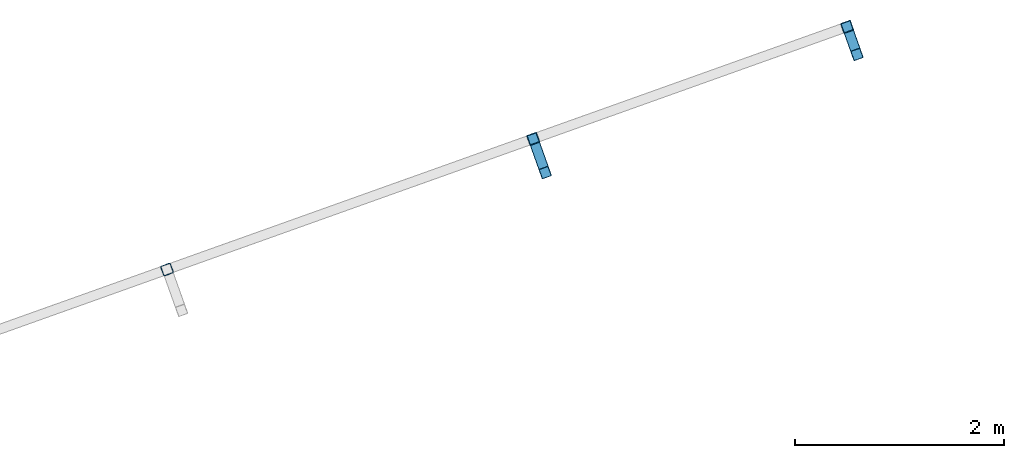
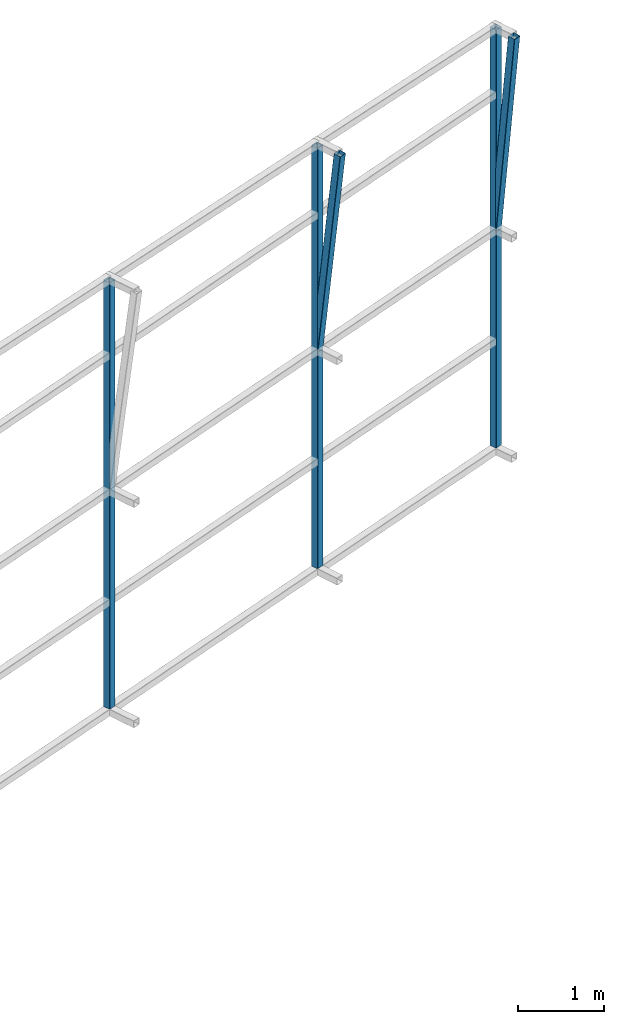
# One storey, part 139 of 215: 3 beams, 2 members, 5 elements without a shape of their own.
"""IFC2X3 building model written with IfcOpenShell, lengths in millimetres."""

from ifc_helpers import new_model, si_unit, frame, origin_with_axes, origin_2d_with_axis, place, context, subcontext, project, spatial, hollow_rectangle, extrude, material, type_object, element, aggregate, save


model = new_model("IFC2X3")

# Units and contexts
model_context = context("Model", 3, precision=1e-05, world=origin_with_axes())
body_context = subcontext(model_context, "Body", "Model", "MODEL_VIEW")
ifc_project = project(units=[si_unit("LENGTHUNIT", "METRE", prefix="MILLI"), si_unit("AREAUNIT", "SQUARE_METRE"), si_unit("VOLUMEUNIT", "CUBIC_METRE"), si_unit("MASSUNIT", "GRAM", prefix="KILO"), si_unit("TIMEUNIT", "SECOND"), si_unit("PLANEANGLEUNIT", "RADIAN"), si_unit("SOLIDANGLEUNIT", "STERADIAN"), si_unit("THERMODYNAMICTEMPERATUREUNIT", "DEGREE_CELSIUS"), si_unit("LUMINOUSINTENSITYUNIT", "LUMEN")], contexts=[model_context])

# Site, building, storey
site_placement = place(None, origin_with_axes())
site = spatial("IfcSite", under=ifc_project, at=site_placement, CompositionType="ELEMENT")
building_placement = place(site_placement, origin_with_axes())
building = spatial("IfcBuilding", under=site, at=building_placement, Name="Undefined", CompositionType="ELEMENT")
storey_placement = place(building_placement, origin_with_axes())
storey = spatial("IfcBuildingStorey", under=building, at=storey_placement, Name="Undefined", CompositionType="ELEMENT", Elevation=0.0)

# Assembly, beam
assembly_1_placement = place(storey_placement, origin_with_axes())
assembly_1 = element("IfcElementAssembly", 1, at=assembly_1_placement, inside=storey, Name="Steel Assembly", AssemblyPlace="NOTDEFINED", PredefinedType="RIGID_FRAME")
ifc_material = material(Name="STEEL/S275JR")
beam_type = type_object("IfcBeamType", PredefinedType="NOTDEFINED")
beam_1_placement = place(assembly_1_placement, frame((141711.296167007, 89162.5195022779, 6137.12183073591), z_axis=(0.941802170974673, 0.33616762299096, 0.0), x_axis=(0.0, 0.0, -1.0)))
beam_1 = element("IfcBeam", 2, at=beam_1_placement, type_object=beam_type, material=ifc_material, Name="LISSE", context=body_context, shape_type="SweptSolid", body=[
    extrude(hollow_rectangle(XDim=100.0, YDim=100.0, WallThickness=4.0, InnerFilletRadius=4.0, OuterFilletRadius=8.0, at=origin_2d_with_axis()), frame((5937.11995354671, -9.2082572249542e-21, 0.0), z_axis=(-1.0, 0.0, 0.0), x_axis=(-6.93889390390723e-18, -1.0, -3.46944695195361e-18)), (0.0, 0.0, 1.0), 5937.1),
])
aggregate(assembly_1, [beam_1])

assembly_2_placement = place(storey_placement, origin_with_axes())
assembly_2 = element("IfcElementAssembly", 3, at=assembly_2_placement, inside=storey, Name="Steel Assembly", AssemblyPlace="NOTDEFINED", PredefinedType="RIGID_FRAME")
beam_2_placement = place(assembly_2_placement, frame((138210.531046494, 87912.975503346, 6218.92471693943), z_axis=(0.941802170974673, 0.33616762299096, 0.0), x_axis=(0.0, 0.0, -1.0)))
beam_2 = element("IfcBeam", 4, at=beam_2_placement, type_object=beam_type, material=ifc_material, Name="LISSE", context=body_context, shape_type="SweptSolid", body=[
    extrude(hollow_rectangle(XDim=100.0, YDim=100.0, WallThickness=4.0, InnerFilletRadius=4.0, OuterFilletRadius=8.0, at=origin_2d_with_axis()), frame((6018.92282407589, 7.27595755692796e-12, -6.37278242371647e-19), z_axis=(-1.0, 0.0, 0.0), x_axis=(-6.93889390390723e-18, -1.0, -3.46944695195361e-18)), (0.0, 0.0, 1.0), 6018.9),
])
aggregate(assembly_2, [beam_2])

assembly_3_placement = place(storey_placement, origin_with_axes())
assembly_3 = element("IfcElementAssembly", 5, at=assembly_3_placement, inside=storey, Name="Steel Assembly", AssemblyPlace="NOTDEFINED", PredefinedType="RIGID_FRAME")
beam_3_placement = place(assembly_3_placement, frame((144712.718473174, 90233.9591967798, 6105.72538615049), z_axis=(0.941802170974673, 0.33616762299096, 0.0), x_axis=(0.0, 0.0, -1.0)))
beam_3 = element("IfcBeam", 6, at=beam_3_placement, type_object=beam_type, material=ifc_material, Name="LISSE", context=body_context, shape_type="SweptSolid", body=[
    extrude(hollow_rectangle(XDim=100.0, YDim=100.0, WallThickness=4.0, InnerFilletRadius=4.0, OuterFilletRadius=8.0, at=origin_2d_with_axis()), frame((5901.49353703772, 1.22040025973615e-21, 3.05100064934037e-22), z_axis=(-1.0, 0.0, 0.0), x_axis=(-6.93889390390723e-18, -1.0, -3.46944695195361e-18)), (0.0, 0.0, 1.0), 5901.5),
])
aggregate(assembly_3, [beam_3])

# Assembly, member
assembly_4_placement = place(storey_placement, origin_with_axes())
assembly_4 = element("IfcElementAssembly", 7, at=assembly_4_placement, inside=storey, Name="Steel Assembly", AssemblyPlace="NOTDEFINED", PredefinedType="RIGID_FRAME")
member_type = type_object("IfcMemberType", PredefinedType="NOTDEFINED")
member_1_placement = place(assembly_4_placement, frame((141826.607165228, 88839.4666735872, 6176.83291466557), z_axis=(0.941802170974673, 0.33616762299096, 0.0), x_axis=(-0.0392622070110161, 0.109996649030867, -0.993156189278708)))
member_1 = element("IfcMember", 8, at=member_1_placement, type_object=member_type, material=ifc_material, Name="LISSE", context=body_context, shape_type="SweptSolid", body=[
    extrude(hollow_rectangle(XDim=100.0, YDim=100.0, WallThickness=4.0, InnerFilletRadius=4.0, OuterFilletRadius=8.0, at=origin_2d_with_axis()), frame((2936.93483081018, 0.0, -2.91198755795164e-11), z_axis=(-1.0, 0.0, 0.0), x_axis=(-6.93889390390723e-18, -1.0, -3.46944695195361e-18)), (0.0, 0.0, 1.0), 2936.9),
])
aggregate(assembly_4, [member_1])

assembly_5_placement = place(storey_placement, origin_with_axes())
assembly_5 = element("IfcElementAssembly", 9, at=assembly_5_placement, inside=storey, Name="Steel Assembly", AssemblyPlace="NOTDEFINED", PredefinedType="RIGID_FRAME")
member_2_placement = place(assembly_5_placement, frame((144807.276902429, 89969.0457176326, 6105.72538614411), z_axis=(0.941802170974673, 0.33616762299096, 0.0), x_axis=(-0.0330670670033487, 0.0926401990093788, -0.995150422100749)))
member_2 = element("IfcMember", 10, at=member_2_placement, type_object=member_type, material=ifc_material, Name="LISSE", context=body_context, shape_type="SweptSolid", body=[
    extrude(hollow_rectangle(XDim=100.0, YDim=100.0, WallThickness=4.0, InnerFilletRadius=4.0, OuterFilletRadius=8.0, at=origin_2d_with_axis()), frame((2859.5953063474, 7.27595761418343e-12, 9.56200134575916e-15), z_axis=(-1.0, 0.0, 0.0), x_axis=(-6.93889390390723e-18, -1.0, -3.46944695195361e-18)), (0.0, 0.0, 1.0), 2859.6),
])
aggregate(assembly_5, [member_2])

save(model, "model.ifc")
